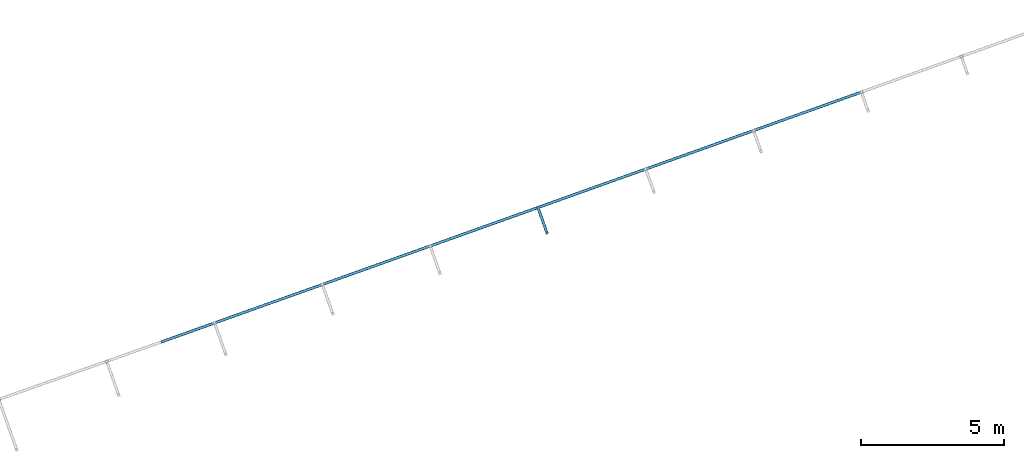
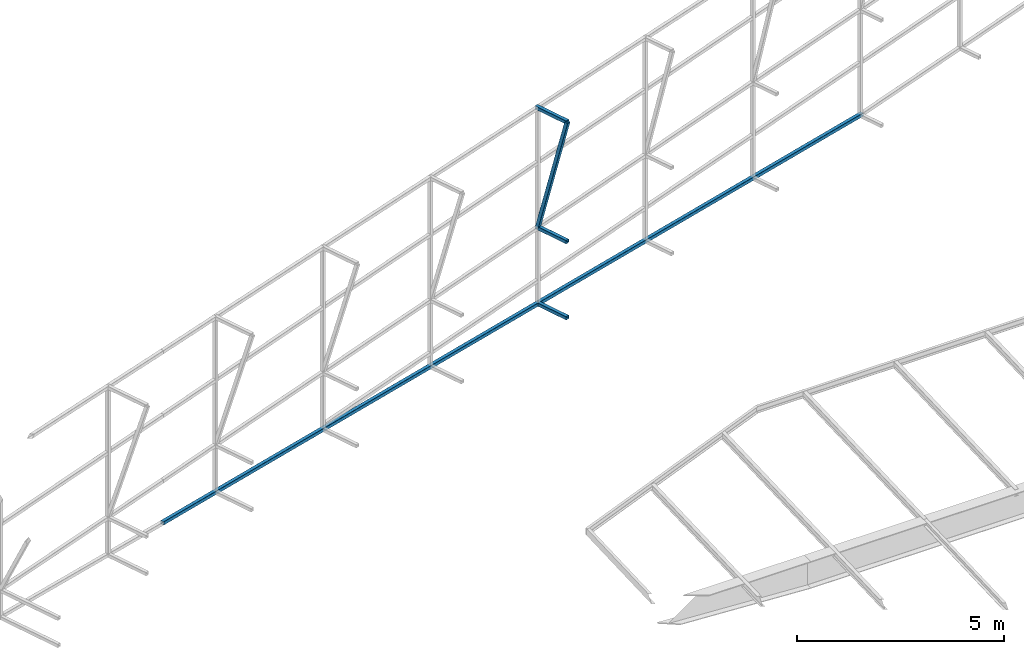
# One storey, part 129 of 215: 4 beams, 1 member, 5 elements without a shape of their own.
"""IFC2X3 building model written with IfcOpenShell, lengths in millimetres."""

from ifc_helpers import new_model, si_unit, frame, origin_with_axes, origin_2d_with_axis, place, context, subcontext, project, spatial, hollow_rectangle, extrude, material, type_object, element, aggregate, save


model = new_model("IFC2X3")

# Units and contexts
model_context = context("Model", 3, precision=1e-05, world=origin_with_axes())
body_context = subcontext(model_context, "Body", "Model", "MODEL_VIEW")
ifc_project = project(units=[si_unit("LENGTHUNIT", "METRE", prefix="MILLI"), si_unit("AREAUNIT", "SQUARE_METRE"), si_unit("VOLUMEUNIT", "CUBIC_METRE"), si_unit("MASSUNIT", "GRAM", prefix="KILO"), si_unit("TIMEUNIT", "SECOND"), si_unit("PLANEANGLEUNIT", "RADIAN"), si_unit("SOLIDANGLEUNIT", "STERADIAN"), si_unit("THERMODYNAMICTEMPERATUREUNIT", "DEGREE_CELSIUS"), si_unit("LUMINOUSINTENSITYUNIT", "LUMEN")], contexts=[model_context])

# Site, building, storey
site_placement = place(None, origin_with_axes())
site = spatial("IfcSite", under=ifc_project, at=site_placement, CompositionType="ELEMENT")
building_placement = place(site_placement, origin_with_axes())
building = spatial("IfcBuilding", under=site, at=building_placement, Name="Undefined", CompositionType="ELEMENT")
storey_placement = place(building_placement, origin_with_axes())
storey = spatial("IfcBuildingStorey", under=building, at=storey_placement, Name="Undefined", CompositionType="ELEMENT", Elevation=0.0)

# Assembly, beam
assembly_1_placement = place(storey_placement, origin_with_axes())
assembly_1 = element("IfcElementAssembly", 1, at=assembly_1_placement, inside=storey, Name="Steel Assembly", AssemblyPlace="NOTDEFINED", PredefinedType="RIGID_FRAME")
ifc_material = material(Name="STEEL/S275JR")
beam_type = type_object("IfcBeamType", PredefinedType="NOTDEFINED")
beam_1_placement = place(assembly_1_placement, frame((113193.700097951, 77988.4548256216, 1013.81257151377), z_axis=(0.941802170974673, 0.33616762299096, 0.0), x_axis=(-0.336167626855526, 0.941802169595252, 0.0)))
beam_1 = element("IfcBeam", 2, at=beam_1_placement, type_object=beam_type, material=ifc_material, Name="LISSE", context=body_context, shape_type="SweptSolid", body=[
    extrude(hollow_rectangle(XDim=100.0, YDim=100.0, WallThickness=4.0, InnerFilletRadius=4.0, OuterFilletRadius=8.0, at=origin_2d_with_axis()), frame((987.23586619095, 1.13686837721616e-13, -2.91586330562028e-11), z_axis=(-1.0, 0.0, 0.0), x_axis=(-6.93889390390723e-18, -1.0, -3.46944695195361e-18)), (0.0, 0.0, 1.0), 987.2),
])
aggregate(assembly_1, [beam_1])

assembly_2_placement = place(storey_placement, origin_with_axes())
assembly_2 = element("IfcElementAssembly", 3, at=assembly_2_placement, inside=storey, Name="Steel Assembly", AssemblyPlace="NOTDEFINED", PredefinedType="RIGID_FRAME")
beam_2_placement = place(assembly_2_placement, frame((113193.700092224, 77988.4548248118, 3259.9979099935), z_axis=(0.941802170974673, 0.33616762299096, 0.0), x_axis=(-0.336167626855526, 0.941802169595252, 0.0)))
beam_2 = element("IfcBeam", 4, at=beam_2_placement, type_object=beam_type, material=ifc_material, Name="LISSE", context=body_context, shape_type="SweptSolid", body=[
    extrude(hollow_rectangle(XDim=100.0, YDim=100.0, WallThickness=4.0, InnerFilletRadius=4.0, OuterFilletRadius=8.0, at=origin_2d_with_axis()), frame((987.23586619095, 1.13686837721616e-13, -2.91586330562028e-11), z_axis=(-1.0, 0.0, 0.0), x_axis=(-6.93889390390723e-18, -1.0, -3.46944695195361e-18)), (0.0, 0.0, 1.0), 987.2),
])
aggregate(assembly_2, [beam_2])

assembly_3_placement = place(storey_placement, origin_with_axes())
assembly_3 = element("IfcElementAssembly", 5, at=assembly_3_placement, inside=storey, Name="Steel Assembly", AssemblyPlace="NOTDEFINED", PredefinedType="RIGID_FRAME")
beam_3_placement = place(assembly_3_placement, frame((113193.700099074, 77988.4548257726, 6787.60739466497), z_axis=(0.941802170974673, 0.33616762299096, 0.0), x_axis=(-0.336167626855526, 0.941802169595252, 0.0)))
beam_3 = element("IfcBeam", 6, at=beam_3_placement, type_object=beam_type, material=ifc_material, Name="LISSE", context=body_context, shape_type="SweptSolid", body=[
    extrude(hollow_rectangle(XDim=100.0, YDim=100.0, WallThickness=4.0, InnerFilletRadius=4.0, OuterFilletRadius=8.0, at=origin_2d_with_axis()), frame((987.23586619095, 1.13686837721616e-13, -2.91586330562028e-11), z_axis=(-1.0, 0.0, 0.0), x_axis=(-6.93889390390723e-18, -1.0, -3.46944695195361e-18)), (0.0, 0.0, 1.0), 987.2),
])
aggregate(assembly_3, [beam_3])

assembly_4_placement = place(storey_placement, origin_with_axes())
assembly_4 = element("IfcElementAssembly", 7, at=assembly_4_placement, inside=storey, Name="Steel Assembly", AssemblyPlace="NOTDEFINED", PredefinedType="RIGID_FRAME")
beam_4_placement = place(assembly_4_placement, frame((99678.9755495725, 74159.578816834, 2015.73327438136), z_axis=(-0.0671556269825424, -0.0239705829937707, -0.997454526740703), x_axis=(0.939404838870399, 0.33531191695374, -0.0713054489901626)))
beam_4 = element("IfcBeam", 8, at=beam_4_placement, type_object=beam_type, material=ifc_material, Name="LISSE", context=body_context, shape_type="SweptSolid", body=[
    extrude(hollow_rectangle(XDim=100.0, YDim=100.0, WallThickness=4.0, InnerFilletRadius=4.0, OuterFilletRadius=8.0, at=origin_2d_with_axis()), frame((26167.1259070555, -6.11211344450317e-12, 0.0), z_axis=(-1.0, 0.0, 0.0), x_axis=(-6.93889390390723e-18, -1.0, -3.46944695195361e-18)), (0.0, 0.0, 1.0), 26167.1),
])
aggregate(assembly_4, [beam_4])

# Assembly, member
assembly_5_placement = place(storey_placement, origin_with_axes())
assembly_5 = element("IfcElementAssembly", 9, at=assembly_5_placement, inside=storey, Name="Steel Assembly", AssemblyPlace="NOTDEFINED", PredefinedType="RIGID_FRAME")
member_type = type_object("IfcMemberType", PredefinedType="NOTDEFINED")
member_placement = place(assembly_5_placement, frame((113193.700099074, 77988.4548257726, 6787.60739466497), z_axis=(0.941802170974673, 0.33616762299096, 0.0), x_axis=(-0.0863202939570303, 0.241833634879619, -0.966470537518906)))
member = element("IfcMember", 10, at=member_placement, type_object=member_type, material=ifc_material, Name="LISSE", context=body_context, shape_type="SweptSolid", body=[
    extrude(hollow_rectangle(XDim=100.0, YDim=100.0, WallThickness=4.0, InnerFilletRadius=4.0, OuterFilletRadius=8.0, at=origin_2d_with_axis()), frame((3649.99174589248, 7.07334237038435e-12, 6.69242225310006e-14), z_axis=(-1.0, 0.0, 0.0), x_axis=(-6.93889390390723e-18, -1.0, -3.46944695195361e-18)), (0.0, 0.0, 1.0), 3650.0),
])
aggregate(assembly_5, [member])

save(model, "model.ifc")
